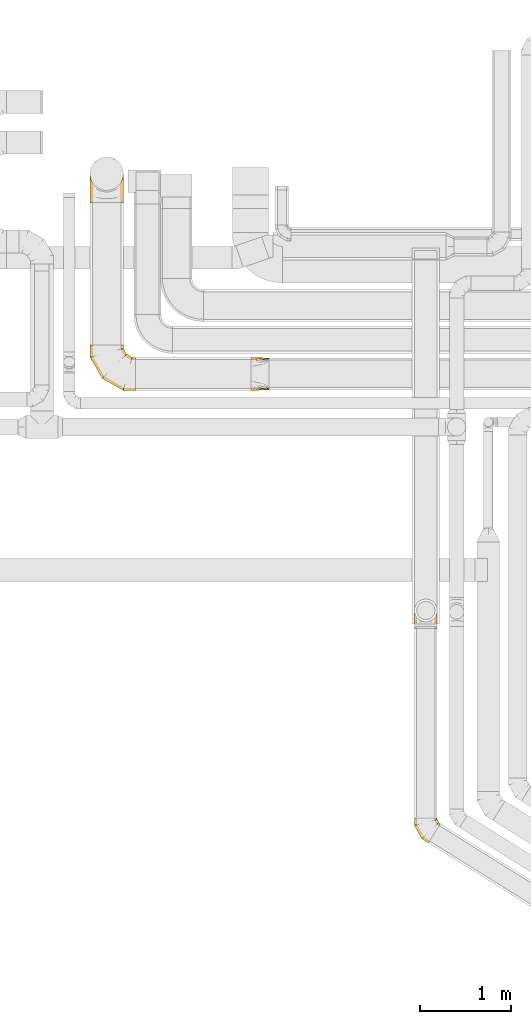
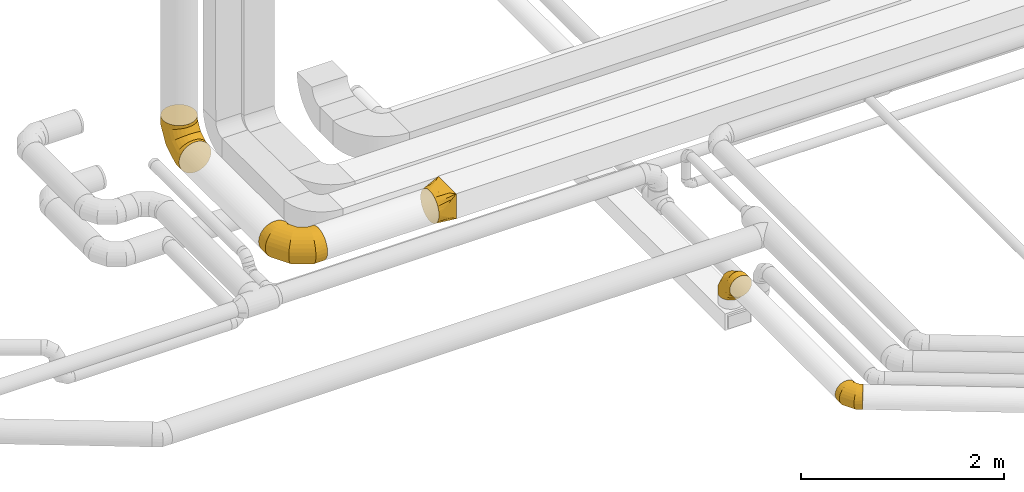
# One storey, part 8 of 92: 5 coverings.
"""IFC2X3 building model written with IfcOpenShell, lengths in millimetres."""

from ifc_helpers import new_model, entity, si_unit, converted_unit, derived_unit, direction, frame, origin, place, context, subcontext, project, spatial, faceted_brep, element, save


model = new_model("IFC2X3")

# Units and contexts
model_context = context("Model", 3, precision=0.01, world=origin(), true_north=direction((6.12303176911189e-17, 1.0)))
body_context = subcontext(model_context, "Body", "Model", "MODEL_VIEW")
ifc_project = project(units=[si_unit("LENGTHUNIT", "METRE", prefix="MILLI"), si_unit("AREAUNIT", "SQUARE_METRE"), si_unit("VOLUMEUNIT", "CUBIC_METRE"), converted_unit("PLANEANGLEUNIT", "DEGREE", entity("IfcRatioMeasure", 0.0174532925199433), si_unit("PLANEANGLEUNIT", "RADIAN"), dimensions=[0, 0, 0, 0, 0, 0, 0]), si_unit("MASSUNIT", "GRAM", prefix="KILO"), derived_unit("MASSDENSITYUNIT", [(si_unit("MASSUNIT", "GRAM", prefix="KILO"), 1), (si_unit("LENGTHUNIT", "METRE"), -3)]), derived_unit("MOMENTOFINERTIAUNIT", [(si_unit("LENGTHUNIT", "METRE"), 4)]), si_unit("TIMEUNIT", "SECOND"), si_unit("FREQUENCYUNIT", "HERTZ"), si_unit("THERMODYNAMICTEMPERATUREUNIT", "DEGREE_CELSIUS"), derived_unit("THERMALTRANSMITTANCEUNIT", [(si_unit("MASSUNIT", "GRAM", prefix="KILO"), 1), (si_unit("THERMODYNAMICTEMPERATUREUNIT", "KELVIN"), -1), (si_unit("TIMEUNIT", "SECOND"), -3)]), derived_unit("VOLUMETRICFLOWRATEUNIT", [(si_unit("LENGTHUNIT", "METRE"), 3), (si_unit("TIMEUNIT", "SECOND"), -1)]), derived_unit("MASSFLOWRATEUNIT", [(si_unit("MASSUNIT", "GRAM", prefix="KILO"), 1), (si_unit("TIMEUNIT", "SECOND"), -1)]), derived_unit("ROTATIONALFREQUENCYUNIT", [(si_unit("TIMEUNIT", "SECOND"), -1)]), si_unit("ELECTRICCURRENTUNIT", "AMPERE"), si_unit("ELECTRICVOLTAGEUNIT", "VOLT"), si_unit("POWERUNIT", "WATT"), si_unit("FORCEUNIT", "NEWTON", prefix="KILO"), si_unit("ILLUMINANCEUNIT", "LUX"), si_unit("LUMINOUSFLUXUNIT", "LUMEN"), si_unit("LUMINOUSINTENSITYUNIT", "CANDELA"), derived_unit("USERDEFINED", [(si_unit("MASSUNIT", "GRAM", prefix="KILO"), -1), (si_unit("LENGTHUNIT", "METRE"), -2), (si_unit("TIMEUNIT", "SECOND"), 3), (si_unit("LUMINOUSFLUXUNIT", "LUMEN"), 1)]), derived_unit("LINEARVELOCITYUNIT", [(si_unit("LENGTHUNIT", "METRE"), 1), (si_unit("TIMEUNIT", "SECOND"), -1)]), si_unit("PRESSUREUNIT", "PASCAL"), derived_unit("USERDEFINED", [(si_unit("LENGTHUNIT", "METRE"), -2), (si_unit("MASSUNIT", "GRAM", prefix="KILO"), 1), (si_unit("TIMEUNIT", "SECOND"), -2)]), derived_unit("LINEARFORCEUNIT", [(si_unit("MASSUNIT", "GRAM", prefix="KILO"), 1), (si_unit("LENGTHUNIT", "METRE"), 1), (si_unit("TIMEUNIT", "SECOND"), -2), (si_unit("LENGTHUNIT", "METRE"), -1)]), derived_unit("PLANARFORCEUNIT", [(si_unit("MASSUNIT", "GRAM", prefix="KILO"), 1), (si_unit("LENGTHUNIT", "METRE"), 1), (si_unit("TIMEUNIT", "SECOND"), -2), (si_unit("LENGTHUNIT", "METRE"), -2)])], contexts=[model_context])

# Site, building, storey
site_placement = place(None, origin())
site = spatial("IfcSite", under=ifc_project, at=site_placement, CompositionType="ELEMENT")
building_placement = place(site_placement, origin())
building = spatial("IfcBuilding", under=site, at=building_placement, CompositionType="ELEMENT")
storey_placement = place(building_placement, frame((0.0, 0.0, 4200.0)))
storey = spatial("IfcBuildingStorey", under=building, at=storey_placement, CompositionType="ELEMENT", Elevation=4200.0)

# Coverings
covering_1_placement = place(storey_placement, frame((11977.68, 6670.24, 3223.4)))
element("IfcCovering", 1, at=covering_1_placement, inside=storey, PredefinedType="INSULATION", context=body_context, shape_type="Brep", body=[
    faceted_brep([(283.61, 208.42, 87.97), (286.85, 213.61, 126.6), (283.61, 208.42, 165.22), (274.2, 193.36, 200.07), (259.55, 169.91, 227.72), (241.08, 140.36, 245.48), (220.61, 107.6, 251.6), (200.14, 74.84, 245.48), (181.68, 45.29, 227.72), (167.02, 21.84, 200.07), (157.62, 6.78, 165.22), (154.37, 1.6, 126.6), (157.62, 6.78, 87.97), (167.02, 21.84, 53.12), (181.68, 45.29, 25.47), (200.14, 74.84, 7.71), (220.61, 107.6, 1.6), (241.08, 140.36, 7.71), (259.55, 169.91, 25.47), (274.2, 193.36, 53.12), (5.85, 277.21, 94.24), (1.6, 277.21, 126.6), (5.85, 277.21, 158.95), (18.34, 277.21, 189.1), (38.21, 277.21, 214.98), (64.1, 277.21, 234.85), (94.24, 277.21, 247.34), (126.6, 277.21, 251.6), (158.95, 277.21, 247.34), (189.1, 277.21, 234.85), (214.98, 277.21, 214.98), (234.85, 277.21, 189.1), (247.34, 277.21, 158.95), (251.6, 277.21, 126.6), (247.34, 277.21, 94.24), (234.85, 277.21, 64.1), (214.98, 277.21, 38.21), (189.1, 277.21, 18.34), (158.95, 277.21, 5.85), (126.6, 277.21, 1.6), (94.24, 277.21, 5.85), (64.1, 277.21, 18.34), (38.21, 277.21, 38.21), (18.34, 277.21, 64.1), (1.6, 193.16, 126.6), (5.85, 194.26, 158.95), (18.34, 197.49, 189.1), (38.21, 202.63, 214.98), (64.1, 209.32, 234.85), (94.24, 217.12, 247.34), (126.6, 225.49, 251.6), (158.95, 233.86, 247.34), (189.1, 241.65, 234.85), (214.98, 248.35, 214.98), (234.85, 253.48, 189.1), (247.34, 256.71, 158.95), (251.6, 257.82, 126.6), (247.34, 256.71, 94.24), (234.85, 253.48, 64.1), (214.98, 248.35, 38.21), (158.95, 233.86, 5.85), (126.6, 225.49, 1.6), (189.1, 241.65, 18.34), (94.24, 217.12, 5.85), (64.1, 209.32, 18.34), (38.21, 202.63, 38.21), (18.34, 197.49, 64.1), (5.85, 194.26, 94.24), (83.09, 46.14, 126.6), (86.29, 49.16, 158.95), (95.64, 58.04, 189.1), (110.52, 72.17, 214.98), (129.92, 90.57, 234.85), (152.51, 112.01, 247.34), (176.75, 135.01, 251.6), (200.99, 158.01, 247.34), (223.58, 179.45, 234.85), (242.97, 197.86, 214.98), (257.86, 211.98, 189.1), (267.21, 220.86, 158.95), (270.4, 223.89, 126.6), (267.21, 220.86, 94.24), (257.86, 211.98, 64.1), (242.97, 197.86, 38.21), (200.99, 158.01, 5.85), (176.75, 135.01, 1.6), (223.58, 179.45, 18.34), (152.51, 112.01, 5.85), (129.92, 90.57, 18.34), (110.52, 72.17, 38.21), (95.64, 58.04, 64.1), (86.29, 49.16, 94.24)], [[[0, 1, 2, 3, 4, 5, 6, 7, 8, 9, 10, 11, 12, 13, 14, 15, 16, 17, 18, 19]], [[20, 21, 22, 23, 24, 25, 26, 27, 28, 29, 30, 31, 32, 33, 34, 35, 36, 37, 38, 39, 40, 41, 42, 43]], [[21, 44, 45, 22]], [[22, 45, 46, 23]], [[47, 24, 23, 46]], [[24, 47, 48, 25]], [[25, 48, 49, 26]], [[50, 27, 26, 49]], [[51, 52, 29, 28]], [[50, 51, 28, 27]], [[53, 30, 29, 52]], [[54, 55, 32, 31]], [[54, 31, 30, 53]], [[56, 33, 32, 55]], [[57, 58, 35, 34]], [[56, 57, 34, 33]], [[36, 35, 58, 59]], [[60, 61, 39, 38]], [[62, 60, 38, 37]], [[59, 62, 37, 36]], [[40, 39, 61, 63]], [[41, 40, 63, 64]], [[64, 65, 42, 41]], [[20, 43, 66, 67]], [[21, 20, 67, 44]], [[65, 66, 43, 42]], [[45, 44, 68, 69]], [[46, 45, 69, 70]], [[70, 71, 47, 46]], [[48, 47, 71, 72]], [[49, 48, 72, 73]], [[50, 49, 73, 74]], [[75, 76, 52, 51]], [[74, 75, 51, 50]], [[53, 52, 76, 77]], [[78, 79, 55, 54]], [[77, 78, 54, 53]], [[56, 55, 79, 80]], [[81, 82, 58, 57]], [[80, 81, 57, 56]], [[59, 58, 82, 83]], [[84, 85, 61, 60]], [[86, 84, 60, 62]], [[83, 86, 62, 59]], [[63, 61, 85, 87]], [[64, 63, 87, 88]], [[65, 64, 88, 89]], [[67, 66, 90, 91]], [[44, 67, 91, 68]], [[89, 90, 66, 65]], [[69, 11, 10]], [[70, 10, 9]], [[11, 69, 68]], [[69, 10, 70]], [[9, 71, 70]], [[72, 8, 7]], [[73, 7, 6]], [[71, 8, 72]], [[72, 7, 73]], [[6, 74, 73]], [[8, 71, 9]], [[75, 6, 5]], [[76, 5, 4]], [[75, 74, 6]], [[76, 75, 5]], [[4, 77, 76]], [[78, 3, 2]], [[79, 2, 1]], [[78, 77, 3]], [[80, 79, 1]], [[78, 2, 79]], [[3, 77, 4]], [[81, 1, 0]], [[82, 0, 19]], [[81, 80, 1]], [[82, 81, 0]], [[19, 83, 82]], [[86, 18, 17]], [[84, 17, 16]], [[86, 83, 18]], [[85, 84, 16]], [[86, 17, 84]], [[18, 83, 19]], [[87, 16, 15]], [[88, 15, 14]], [[16, 87, 85]], [[87, 15, 88]], [[14, 89, 88]], [[90, 13, 12]], [[91, 12, 11]], [[89, 13, 90]], [[91, 90, 12]], [[68, 91, 11]], [[13, 89, 14]]]),
])
covering_2_placement = place(storey_placement, frame((8417.31, 11635.59, 3108.4)))
element("IfcCovering", 2, at=covering_2_placement, inside=storey, PredefinedType="INSULATION", context=body_context, shape_type="Brep", body=[
    faceted_brep([(499.1, 26.05, 275.35), (499.1, 7.81, 231.33), (499.1, 1.6, 184.1), (499.1, 7.81, 136.86), (499.1, 26.05, 92.85), (499.1, 55.05, 55.05), (499.1, 92.85, 26.05), (499.1, 136.86, 7.81), (499.1, 184.1, 1.6), (499.1, 231.33, 7.81), (499.1, 275.35, 26.05), (499.1, 313.14, 55.05), (499.1, 342.14, 92.85), (499.1, 360.38, 136.86), (499.1, 366.6, 184.1), (499.1, 360.38, 231.33), (499.1, 342.14, 275.35), (499.1, 313.14, 313.14), (499.1, 275.35, 342.14), (499.1, 231.33, 360.38), (499.1, 184.1, 366.6), (499.1, 136.86, 360.38), (499.1, 92.85, 342.14), (499.1, 55.05, 313.14), (26.05, 499.1, 92.85), (7.81, 499.1, 136.86), (1.6, 499.1, 184.1), (7.81, 499.1, 231.33), (26.05, 499.1, 275.35), (55.05, 499.1, 313.14), (92.85, 499.1, 342.14), (136.86, 499.1, 360.38), (184.1, 499.1, 366.6), (231.33, 499.1, 360.38), (275.35, 499.1, 342.14), (313.14, 499.1, 313.14), (342.14, 499.1, 275.35), (360.38, 499.1, 231.33), (366.6, 499.1, 184.1), (360.38, 499.1, 136.86), (342.14, 499.1, 92.85), (313.14, 499.1, 55.05), (275.35, 499.1, 26.05), (231.33, 499.1, 7.81), (184.1, 499.1, 1.6), (136.86, 499.1, 7.81), (92.85, 499.1, 26.05), (55.05, 499.1, 55.05), (1.6, 365.79, 184.1), (6.17, 367.02, 224.71), (19.67, 370.63, 263.28), (41.41, 376.46, 297.88), (70.31, 384.2, 326.78), (104.91, 393.47, 348.52), (143.49, 403.81, 362.02), (184.1, 414.69, 366.6), (224.71, 425.57, 362.02), (263.28, 435.91, 348.52), (297.88, 445.18, 326.78), (326.78, 452.92, 297.88), (348.52, 458.75, 263.28), (362.02, 462.37, 224.71), (366.6, 463.59, 184.1), (348.52, 458.75, 104.91), (326.78, 452.92, 70.31), (362.02, 462.37, 143.49), (297.88, 445.18, 41.41), (263.28, 435.91, 19.67), (224.71, 425.57, 6.17), (184.1, 414.69, 1.6), (143.49, 403.81, 6.17), (104.91, 393.47, 19.67), (70.31, 384.2, 41.41), (41.41, 376.46, 70.31), (19.67, 370.63, 104.91), (6.17, 367.02, 143.49), (134.9, 134.9, 184.1), (138.25, 138.25, 224.71), (148.13, 148.13, 263.28), (164.05, 164.05, 297.88), (185.2, 185.2, 326.78), (210.53, 210.53, 348.52), (238.77, 238.77, 362.02), (268.5, 268.5, 366.6), (298.23, 298.23, 362.02), (326.47, 326.47, 348.52), (351.8, 351.8, 326.78), (372.95, 372.95, 297.88), (388.87, 388.87, 263.28), (398.75, 398.75, 224.71), (402.1, 402.1, 184.1), (398.75, 398.75, 143.49), (388.87, 388.87, 104.91), (372.95, 372.95, 70.31), (351.8, 351.8, 41.41), (326.47, 326.47, 19.67), (298.23, 298.23, 6.17), (268.5, 268.5, 1.6), (238.77, 238.77, 6.17), (210.53, 210.53, 19.67), (185.2, 185.2, 41.41), (164.05, 164.05, 70.31), (148.13, 148.13, 104.91), (138.25, 138.25, 143.49), (365.79, 1.6, 184.1), (367.02, 6.17, 224.71), (370.63, 19.67, 263.28), (376.46, 41.41, 297.88), (384.2, 70.31, 326.78), (393.47, 104.91, 348.52), (403.81, 143.49, 362.02), (414.69, 184.1, 366.6), (425.57, 224.71, 362.02), (435.91, 263.28, 348.52), (445.18, 297.88, 326.78), (452.92, 326.78, 297.88), (458.75, 348.52, 263.28), (462.37, 362.02, 224.71), (463.59, 366.6, 184.1), (462.37, 362.02, 143.49), (458.75, 348.52, 104.91), (452.92, 326.78, 70.31), (445.18, 297.88, 41.41), (435.91, 263.28, 19.67), (425.57, 224.71, 6.17), (414.69, 184.1, 1.6), (403.81, 143.49, 6.17), (393.47, 104.91, 19.67), (384.2, 70.31, 41.41), (376.46, 41.41, 70.31), (370.63, 19.67, 104.91), (367.02, 6.17, 143.49)], [[[0, 1, 2, 3, 4, 5, 6, 7, 8, 9, 10, 11, 12, 13, 14, 15, 16, 17, 18, 19, 20, 21, 22, 23]], [[24, 25, 26, 27, 28, 29, 30, 31, 32, 33, 34, 35, 36, 37, 38, 39, 40, 41, 42, 43, 44, 45, 46, 47]], [[26, 48, 49]], [[27, 49, 50]], [[26, 49, 27]], [[28, 51, 29]], [[28, 27, 50]], [[51, 28, 50]], [[30, 52, 53]], [[31, 53, 54]], [[32, 54, 55]], [[29, 52, 30]], [[30, 53, 31]], [[54, 32, 31]], [[52, 29, 51]], [[56, 57, 33]], [[55, 56, 32]], [[32, 56, 33]], [[34, 58, 35]], [[34, 33, 57]], [[58, 34, 57]], [[59, 60, 36]], [[61, 62, 38]], [[60, 61, 37]], [[35, 59, 36]], [[36, 60, 37]], [[61, 38, 37]], [[59, 35, 58]], [[63, 64, 40]], [[65, 63, 39]], [[62, 65, 38]], [[38, 65, 39]], [[63, 40, 39]], [[64, 41, 40]], [[66, 67, 42]], [[68, 69, 44]], [[67, 68, 43]], [[41, 66, 42]], [[42, 67, 43]], [[68, 44, 43]], [[66, 41, 64]], [[45, 70, 71]], [[46, 71, 72]], [[69, 70, 44]], [[44, 70, 45]], [[71, 46, 45]], [[72, 47, 46]], [[24, 73, 74]], [[74, 75, 25]], [[48, 26, 75]], [[47, 73, 24]], [[24, 74, 25]], [[75, 26, 25]], [[73, 47, 72]], [[49, 48, 76, 77]], [[49, 77, 78, 50]], [[51, 50, 78, 79]], [[79, 80, 52, 51]], [[53, 52, 80, 81]], [[54, 53, 81, 82]], [[55, 54, 82, 83]], [[83, 84, 56, 55]], [[85, 86, 58, 57]], [[84, 85, 57, 56]], [[86, 87, 59, 58]], [[87, 88, 60, 59]], [[89, 90, 62, 61]], [[88, 89, 61, 60]], [[90, 91, 65, 62]], [[92, 93, 64, 63]], [[91, 92, 63, 65]], [[93, 94, 66, 64]], [[94, 95, 67, 66]], [[96, 97, 69, 68]], [[95, 96, 68, 67]], [[70, 69, 97, 98]], [[98, 99, 71, 70]], [[100, 72, 71, 99]], [[100, 101, 73, 72]], [[74, 73, 101, 102]], [[102, 103, 75, 74]], [[76, 48, 75, 103]], [[77, 76, 104, 105]], [[77, 105, 106, 78]], [[79, 78, 106, 107]], [[107, 108, 80, 79]], [[81, 80, 108, 109]], [[82, 81, 109, 110]], [[83, 82, 110, 111]], [[111, 112, 84, 83]], [[113, 114, 86, 85]], [[112, 113, 85, 84]], [[114, 115, 87, 86]], [[115, 116, 88, 87]], [[117, 118, 90, 89]], [[116, 117, 89, 88]], [[118, 119, 91, 90]], [[120, 121, 93, 92]], [[119, 120, 92, 91]], [[121, 122, 94, 93]], [[122, 123, 95, 94]], [[124, 125, 97, 96]], [[123, 124, 96, 95]], [[98, 97, 125, 126]], [[126, 127, 99, 98]], [[128, 100, 99, 127]], [[128, 129, 101, 100]], [[102, 101, 129, 130]], [[130, 131, 103, 102]], [[104, 76, 103, 131]], [[105, 2, 1]], [[106, 1, 0]], [[104, 2, 105]], [[105, 1, 106]], [[0, 107, 106]], [[0, 23, 107]], [[108, 23, 22]], [[109, 22, 21]], [[110, 21, 20]], [[108, 22, 109]], [[109, 21, 110]], [[20, 111, 110]], [[23, 108, 107]], [[112, 20, 19]], [[113, 19, 18]], [[112, 111, 20]], [[114, 113, 18]], [[112, 19, 113]], [[18, 17, 114]], [[115, 17, 16]], [[116, 16, 15]], [[117, 15, 14]], [[116, 115, 16]], [[118, 117, 14]], [[116, 15, 117]], [[17, 115, 114]], [[119, 14, 13]], [[120, 13, 12]], [[119, 118, 14]], [[121, 120, 12]], [[119, 13, 120]], [[12, 11, 121]], [[122, 11, 10]], [[123, 10, 9]], [[124, 9, 8]], [[123, 122, 10]], [[125, 124, 8]], [[123, 9, 124]], [[11, 122, 121]], [[126, 8, 7]], [[127, 7, 6]], [[125, 8, 126]], [[127, 126, 7]], [[128, 127, 6]], [[6, 5, 128]], [[129, 5, 4]], [[130, 4, 3]], [[131, 3, 2]], [[129, 4, 130]], [[131, 130, 3]], [[104, 131, 2]], [[5, 129, 128]]]),
])
covering_3_placement = place(storey_placement, frame((10183.35, 11635.59, 3108.4)))
element("IfcCovering", 3, at=covering_3_placement, inside=storey, PredefinedType="INSULATION", context=body_context, shape_type="Brep", body=[
    faceted_brep([(0.0, 55.05, 313.14), (0.0, 73.95, 327.64), (0.0, 92.85, 342.14), (0.0, 114.85, 351.26), (0.0, 136.86, 360.38), (0.0, 151.73, 362.33), (0.0, 166.6, 364.29), (0.0, 184.1, 366.6), (0.0, 201.59, 364.29), (0.0, 216.46, 362.33), (0.0, 231.33, 360.38), (0.0, 253.34, 351.26), (0.0, 275.35, 342.14), (0.0, 294.24, 327.64), (0.0, 313.14, 313.14), (0.0, 327.64, 294.24), (0.0, 342.14, 275.35), (0.0, 351.26, 253.34), (0.0, 360.38, 231.33), (0.0, 362.33, 216.46), (0.0, 364.29, 201.59), (0.0, 366.6, 184.1), (0.0, 364.29, 166.6), (0.0, 362.33, 151.73), (0.0, 360.38, 136.86), (0.0, 351.26, 114.85), (0.0, 342.14, 92.85), (0.0, 327.64, 73.95), (0.0, 313.14, 55.05), (0.0, 294.24, 40.55), (0.0, 275.35, 26.05), (0.0, 253.34, 16.93), (0.0, 231.33, 7.81), (0.0, 216.46, 5.86), (0.0, 201.59, 3.9), (0.0, 184.1, 1.6), (0.0, 166.6, 3.9), (0.0, 151.73, 5.86), (0.0, 136.86, 7.81), (0.0, 114.85, 16.93), (0.0, 92.85, 26.05), (0.0, 73.95, 40.55), (0.0, 55.05, 55.05), (0.0, 40.55, 73.95), (0.0, 26.05, 92.85), (0.0, 16.93, 114.85), (0.0, 7.81, 136.86), (0.0, 5.86, 151.73), (0.0, 3.9, 166.6), (0.0, 1.6, 184.1), (0.0, 3.9, 201.59), (0.0, 5.86, 216.46), (0.0, 7.81, 231.33), (0.0, 16.93, 253.34), (0.0, 26.05, 275.35), (0.0, 40.55, 294.24), (200.0, 9.1, 366.6), (200.0, 9.1, 66.6), (200.0, 359.1, 66.6), (200.0, 359.1, 366.6), (71.91, 121.17, 24.97), (95.89, 100.2, 32.76), (121.91, 77.42, 41.22), (100.0, 36.1, 57.03), (173.97, 31.87, 58.14), (147.94, 7.14, 97.18), (173.97, 8.12, 81.89), (121.91, 6.17, 112.47), (95.89, 5.19, 127.76), (71.91, 4.29, 141.85), (23.97, 163.12, 9.39), (47.94, 142.15, 17.18), (47.94, 3.39, 155.93), (23.97, 2.49, 170.01), (147.94, 54.65, 49.68), (173.97, 8.12, 342.84), (147.94, 7.14, 319.09), (121.91, 6.17, 295.34), (95.89, 5.19, 271.59), (71.91, 4.29, 249.72), (47.94, 3.39, 227.84), (23.97, 2.49, 205.97), (100.0, 28.28, 335.85), (147.94, 54.65, 366.6), (173.97, 31.87, 366.6), (121.91, 77.42, 366.6), (95.89, 100.2, 366.6), (71.91, 121.17, 366.6), (47.94, 142.15, 366.6), (23.97, 163.12, 366.6), (173.97, 336.32, 366.6), (147.94, 313.55, 366.6), (121.91, 290.77, 366.6), (95.89, 268.0, 366.6), (71.91, 247.02, 366.6), (47.94, 226.05, 366.6), (23.97, 205.07, 366.6), (100.0, 332.1, 343.66), (147.94, 361.05, 319.09), (173.97, 360.07, 342.84), (121.91, 362.02, 295.34), (95.89, 363.0, 271.59), (71.91, 363.9, 249.72), (47.94, 364.8, 227.84), (23.97, 365.7, 205.97), (173.97, 360.07, 81.89), (147.94, 361.05, 97.18), (121.91, 362.02, 112.47), (95.89, 363.0, 127.76), (71.91, 363.9, 141.85), (47.94, 364.8, 155.93), (23.97, 365.7, 170.01), (100.0, 339.91, 64.85), (147.94, 313.55, 49.68), (173.97, 336.32, 58.14), (121.91, 290.77, 41.22), (95.89, 268.0, 32.76), (71.91, 247.02, 24.97), (47.94, 226.05, 17.18), (23.97, 205.07, 9.39)], [[[0, 1, 2, 3, 4, 5, 6, 7, 8, 9, 10, 11, 12, 13, 14, 15, 16, 17, 18, 19, 20, 21, 22, 23, 24, 25, 26, 27, 28, 29, 30, 31, 32, 33, 34, 35, 36, 37, 38, 39, 40, 41, 42, 43, 44, 45, 46, 47, 48, 49, 50, 51, 52, 53, 54, 55]], [[56, 57, 58, 59]], [[60, 61, 62, 39]], [[63, 41, 64]], [[43, 42, 63]], [[38, 60, 39]], [[39, 62, 40]], [[65, 44, 43]], [[43, 63, 66]], [[45, 67, 68, 69]], [[70, 71, 60, 38, 37, 36, 35]], [[47, 46, 69, 72, 73, 49, 48]], [[45, 44, 67]], [[45, 69, 46]], [[44, 65, 67]], [[41, 74, 64]], [[41, 40, 74]], [[57, 63, 64]], [[41, 63, 42]], [[43, 66, 65]], [[63, 57, 66]], [[62, 74, 40]], [[57, 56, 75, 76, 77, 78, 79, 80, 81, 49, 73, 72, 69, 68, 67, 65, 66]], [[79, 78, 77, 53]], [[82, 55, 75]], [[1, 0, 82]], [[52, 79, 53]], [[53, 77, 54]], [[83, 2, 1]], [[1, 82, 84]], [[3, 85, 86, 87]], [[81, 80, 79, 52, 51, 50, 49]], [[5, 4, 87, 88, 89, 7, 6]], [[3, 2, 85]], [[3, 87, 4]], [[2, 83, 85]], [[55, 76, 75]], [[55, 54, 76]], [[56, 82, 75]], [[55, 82, 0]], [[1, 84, 83]], [[82, 56, 84]], [[77, 76, 54]], [[56, 59, 90, 91, 92, 93, 94, 95, 96, 7, 89, 88, 87, 86, 85, 83, 84]], [[94, 93, 92, 11]], [[97, 13, 90]], [[15, 14, 97]], [[10, 94, 11]], [[11, 92, 12]], [[98, 16, 15]], [[15, 97, 99]], [[17, 100, 101, 102]], [[96, 95, 94, 10, 9, 8, 7]], [[19, 18, 102, 103, 104, 21, 20]], [[17, 16, 100]], [[17, 102, 18]], [[16, 98, 100]], [[13, 91, 90]], [[13, 12, 91]], [[59, 97, 90]], [[13, 97, 14]], [[15, 99, 98]], [[97, 59, 99]], [[92, 91, 12]], [[104, 103, 102, 101, 100, 98, 99, 59, 58, 105, 106, 107, 108, 109, 110, 111, 21]], [[109, 108, 107, 25]], [[112, 27, 105]], [[29, 28, 112]], [[24, 109, 25]], [[25, 107, 26]], [[113, 30, 29]], [[29, 112, 114]], [[31, 115, 116, 117]], [[111, 110, 109, 24, 23, 22, 21]], [[33, 32, 117, 118, 119, 35, 34]], [[31, 30, 115]], [[31, 117, 32]], [[30, 113, 115]], [[27, 106, 105]], [[27, 26, 106]], [[58, 112, 105]], [[27, 112, 28]], [[29, 114, 113]], [[112, 58, 114]], [[107, 106, 26]], [[58, 57, 64, 74, 62, 61, 60, 71, 70, 35, 119, 118, 117, 116, 115, 113, 114]]]),
])
covering_4_placement = place(storey_placement, frame((11977.68, 9022.49, 3150.0)))
element("IfcCovering", 4, at=covering_4_placement, inside=storey, PredefinedType="INSULATION", context=body_context, shape_type="Brep", body=[
    faceted_brep([(1.6, 200.0, 0.0), (7.71, 238.63, 0.0), (25.47, 273.47, 0.0), (53.12, 301.13, 0.0), (87.97, 318.88, 0.0), (126.6, 325.0, 0.0), (165.22, 318.88, 0.0), (200.07, 301.13, 0.0), (227.72, 273.47, 0.0), (245.48, 238.63, 0.0), (251.6, 200.0, 0.0), (245.48, 161.37, 0.0), (227.72, 126.53, 0.0), (200.07, 98.87, 0.0), (165.22, 81.12, 0.0), (126.6, 75.0, 0.0), (87.97, 81.12, 0.0), (53.12, 98.87, 0.0), (25.47, 126.53, 0.0), (7.71, 161.37, 0.0), (189.1, 0.0, 308.25), (158.95, 0.0, 320.74), (126.6, 0.0, 325.0), (94.24, 0.0, 320.74), (64.1, 0.0, 308.25), (38.21, 0.0, 288.39), (18.34, 0.0, 262.5), (5.85, 0.0, 232.35), (1.6, 0.0, 200.0), (5.85, 0.0, 167.65), (18.34, 0.0, 137.5), (38.21, 0.0, 111.61), (64.1, 0.0, 91.75), (94.24, 0.0, 79.26), (126.6, 0.0, 75.0), (158.95, 0.0, 79.26), (189.1, 0.0, 91.75), (214.98, 0.0, 111.61), (234.85, 0.0, 137.5), (247.34, 0.0, 167.65), (251.6, 0.0, 200.0), (247.34, 0.0, 232.35), (234.85, 0.0, 262.5), (214.98, 0.0, 288.39), (126.6, 87.08, 325.0), (94.24, 85.94, 320.74), (64.1, 82.6, 308.25), (38.21, 77.27, 288.39), (18.34, 70.34, 262.5), (5.85, 62.26, 232.35), (1.6, 53.59, 200.0), (5.85, 44.92, 167.65), (18.34, 36.84, 137.5), (38.21, 29.91, 111.61), (64.1, 24.58, 91.75), (94.24, 21.24, 79.26), (126.6, 20.1, 75.0), (158.95, 21.24, 79.26), (189.1, 24.58, 91.75), (214.98, 29.91, 111.61), (247.34, 44.92, 167.65), (251.6, 53.59, 200.0), (234.85, 36.84, 137.5), (247.34, 62.26, 232.35), (234.85, 70.34, 262.5), (214.98, 77.27, 288.39), (189.1, 82.6, 308.25), (158.95, 85.94, 320.74), (126.6, 237.92, 237.92), (94.24, 234.8, 234.8), (64.1, 225.66, 225.66), (38.21, 211.11, 211.11), (18.34, 192.16, 192.16), (5.85, 170.09, 170.09), (1.6, 146.41, 146.41), (5.85, 122.73, 122.73), (18.34, 100.66, 100.66), (38.21, 81.71, 81.71), (64.1, 67.16, 67.16), (94.24, 58.02, 58.02), (126.6, 54.9, 54.9), (158.95, 58.02, 58.02), (189.1, 67.16, 67.16), (214.98, 81.71, 81.71), (247.34, 122.73, 122.73), (251.6, 146.41, 146.41), (234.85, 100.66, 100.66), (247.34, 170.09, 170.09), (234.85, 192.16, 192.16), (214.98, 211.11, 211.11), (189.1, 225.66, 225.66), (158.95, 234.8, 234.8), (126.6, 325.0, 87.08), (94.24, 320.74, 85.94), (64.1, 308.25, 82.6), (38.21, 288.39, 77.27), (18.34, 262.5, 70.34), (5.85, 232.35, 62.26), (1.6, 200.0, 53.59), (5.85, 167.65, 44.92), (18.34, 137.5, 36.84), (38.21, 111.61, 29.91), (64.1, 91.75, 24.58), (94.24, 79.26, 21.24), (126.6, 75.0, 20.1), (158.95, 79.26, 21.24), (189.1, 91.75, 24.58), (214.98, 111.61, 29.91), (247.34, 167.65, 44.92), (251.6, 200.0, 53.59), (234.85, 137.5, 36.84), (247.34, 232.35, 62.26), (234.85, 262.5, 70.34), (214.98, 288.39, 77.27), (189.1, 308.25, 82.6), (158.95, 320.74, 85.94)], [[[0, 1, 2, 3, 4, 5, 6, 7, 8, 9, 10, 11, 12, 13, 14, 15, 16, 17, 18, 19]], [[20, 21, 22, 23, 24, 25, 26, 27, 28, 29, 30, 31, 32, 33, 34, 35, 36, 37, 38, 39, 40, 41, 42, 43]], [[22, 44, 45, 23]], [[23, 45, 46, 24]], [[47, 25, 24, 46]], [[25, 47, 48, 26]], [[26, 48, 49, 27]], [[50, 28, 27, 49]], [[51, 52, 30, 29]], [[50, 51, 29, 28]], [[53, 31, 30, 52]], [[54, 55, 33, 32]], [[54, 32, 31, 53]], [[56, 34, 33, 55]], [[57, 58, 36, 35]], [[56, 57, 35, 34]], [[37, 36, 58, 59]], [[60, 61, 40, 39]], [[62, 60, 39, 38]], [[59, 62, 38, 37]], [[41, 40, 61, 63]], [[42, 41, 63, 64]], [[64, 65, 43, 42]], [[21, 20, 66, 67]], [[22, 21, 67, 44]], [[65, 66, 20, 43]], [[45, 44, 68, 69]], [[46, 45, 69, 70]], [[70, 71, 47, 46]], [[48, 47, 71, 72]], [[49, 48, 72, 73]], [[50, 49, 73, 74]], [[75, 76, 52, 51]], [[74, 75, 51, 50]], [[53, 52, 76, 77]], [[78, 79, 55, 54]], [[77, 78, 54, 53]], [[56, 55, 79, 80]], [[81, 82, 58, 57]], [[80, 81, 57, 56]], [[59, 58, 82, 83]], [[84, 85, 61, 60]], [[86, 84, 60, 62]], [[83, 86, 62, 59]], [[63, 61, 85, 87]], [[64, 63, 87, 88]], [[65, 64, 88, 89]], [[67, 66, 90, 91]], [[44, 67, 91, 68]], [[89, 90, 66, 65]], [[69, 68, 92, 93]], [[70, 69, 93, 94]], [[94, 95, 71, 70]], [[72, 71, 95, 96]], [[73, 72, 96, 97]], [[74, 73, 97, 98]], [[99, 100, 76, 75]], [[98, 99, 75, 74]], [[77, 76, 100, 101]], [[102, 103, 79, 78]], [[101, 102, 78, 77]], [[80, 79, 103, 104]], [[105, 106, 82, 81]], [[104, 105, 81, 80]], [[83, 82, 106, 107]], [[108, 109, 85, 84]], [[110, 108, 84, 86]], [[107, 110, 86, 83]], [[87, 85, 109, 111]], [[88, 87, 111, 112]], [[89, 88, 112, 113]], [[91, 90, 114, 115]], [[68, 91, 115, 92]], [[113, 114, 90, 89]], [[93, 5, 4]], [[94, 4, 3]], [[5, 93, 92]], [[93, 4, 94]], [[3, 95, 94]], [[96, 2, 1]], [[97, 1, 0]], [[95, 2, 96]], [[96, 1, 97]], [[0, 98, 97]], [[2, 95, 3]], [[99, 0, 19]], [[100, 19, 18]], [[99, 98, 0]], [[100, 99, 19]], [[18, 101, 100]], [[16, 15, 103]], [[17, 16, 102]], [[102, 101, 17]], [[104, 103, 15]], [[102, 16, 103]], [[17, 101, 18]], [[105, 15, 14]], [[106, 14, 13]], [[105, 104, 15]], [[106, 105, 14]], [[13, 107, 106]], [[110, 12, 11]], [[108, 11, 10]], [[110, 107, 12]], [[109, 108, 10]], [[110, 11, 108]], [[12, 107, 13]], [[111, 10, 9]], [[112, 9, 8]], [[10, 111, 109]], [[111, 9, 112]], [[8, 113, 112]], [[114, 7, 6]], [[115, 6, 5]], [[113, 7, 114]], [[115, 114, 6]], [[92, 115, 5]], [[7, 113, 8]]]),
])
covering_5_placement = place(storey_placement, frame((8417.31, 13701.72, 3108.4)))
element("IfcCovering", 5, at=covering_5_placement, inside=storey, PredefinedType="INSULATION", context=body_context, shape_type="Brep", body=[
    faceted_brep([(275.35, 473.05, 499.1), (231.33, 491.28, 499.1), (184.1, 497.5, 499.1), (136.86, 491.28, 499.1), (92.85, 473.05, 499.1), (55.05, 444.05, 499.1), (26.05, 406.25, 499.1), (7.81, 362.23, 499.1), (1.6, 315.0, 499.1), (7.81, 267.77, 499.1), (26.05, 223.75, 499.1), (55.05, 185.95, 499.1), (92.85, 156.95, 499.1), (136.86, 138.72, 499.1), (184.1, 132.5, 499.1), (231.33, 138.72, 499.1), (275.35, 156.95, 499.1), (313.14, 185.95, 499.1), (342.14, 223.75, 499.1), (360.38, 267.77, 499.1), (366.6, 315.0, 499.1), (360.38, 362.23, 499.1), (342.14, 406.25, 499.1), (313.14, 444.05, 499.1), (92.85, 0.0, 26.05), (136.86, 0.0, 7.81), (184.1, 0.0, 1.6), (231.33, 0.0, 7.81), (275.35, 0.0, 26.05), (313.14, 0.0, 55.05), (342.14, 0.0, 92.85), (360.38, 0.0, 136.86), (366.6, 0.0, 184.1), (360.38, 0.0, 231.33), (342.14, 0.0, 275.35), (313.14, 0.0, 313.14), (275.35, 0.0, 342.14), (231.33, 0.0, 360.38), (184.1, 0.0, 366.6), (136.86, 0.0, 360.38), (92.85, 0.0, 342.14), (55.05, 0.0, 313.14), (26.05, 0.0, 275.35), (7.81, 0.0, 231.33), (1.6, 0.0, 184.1), (7.81, 0.0, 136.86), (26.05, 0.0, 92.85), (55.05, 0.0, 55.05), (184.1, 133.3, 1.6), (224.71, 132.08, 6.17), (263.28, 128.46, 19.67), (297.88, 122.64, 41.41), (326.78, 114.89, 70.31), (348.52, 105.62, 104.91), (362.02, 95.29, 143.49), (366.6, 84.4, 184.1), (362.02, 73.52, 224.71), (348.52, 63.19, 263.28), (326.78, 53.91, 297.88), (297.88, 46.17, 326.78), (263.28, 40.35, 348.52), (224.71, 36.73, 362.02), (184.1, 35.5, 366.6), (104.91, 40.35, 348.52), (70.31, 46.17, 326.78), (143.49, 36.73, 362.02), (41.41, 53.91, 297.88), (19.67, 63.19, 263.28), (6.17, 73.52, 224.71), (1.6, 84.4, 184.1), (6.17, 95.29, 143.49), (19.67, 105.62, 104.91), (41.41, 114.89, 70.31), (70.31, 122.64, 41.41), (104.91, 128.46, 19.67), (143.49, 132.08, 6.17), (184.1, 364.2, 134.9), (224.71, 360.85, 138.25), (263.28, 350.96, 148.13), (297.88, 335.05, 164.05), (326.78, 313.89, 185.2), (348.52, 288.56, 210.53), (362.02, 260.32, 238.77), (366.6, 230.6, 268.5), (362.02, 200.87, 298.23), (348.52, 172.63, 326.47), (326.78, 147.3, 351.8), (297.88, 126.14, 372.95), (263.28, 110.23, 388.87), (224.71, 100.35, 398.75), (184.1, 97.0, 402.1), (143.49, 100.35, 398.75), (104.91, 110.23, 388.87), (70.31, 126.14, 372.95), (41.41, 147.3, 351.8), (19.67, 172.63, 326.47), (6.17, 200.87, 298.23), (1.6, 230.6, 268.5), (6.17, 260.32, 238.77), (19.67, 288.56, 210.53), (41.41, 313.89, 185.2), (70.31, 335.05, 164.05), (104.91, 350.96, 148.13), (143.49, 360.85, 138.25), (184.1, 497.5, 365.79), (224.71, 492.92, 367.02), (263.28, 479.43, 370.63), (297.88, 457.68, 376.46), (326.78, 428.79, 384.2), (348.52, 394.18, 393.47), (362.02, 355.61, 403.81), (366.6, 315.0, 414.69), (362.02, 274.39, 425.57), (348.52, 235.82, 435.91), (326.78, 201.21, 445.18), (297.88, 172.32, 452.92), (263.28, 150.57, 458.75), (224.71, 137.08, 462.37), (184.1, 132.5, 463.59), (143.49, 137.08, 462.37), (104.91, 150.57, 458.75), (70.31, 172.32, 452.92), (41.41, 201.21, 445.18), (19.67, 235.82, 435.91), (6.17, 274.39, 425.57), (1.6, 315.0, 414.69), (6.17, 355.61, 403.81), (19.67, 394.18, 393.47), (41.41, 428.79, 384.2), (70.31, 457.68, 376.46), (104.91, 479.43, 370.63), (143.49, 492.92, 367.02)], [[[0, 1, 2, 3, 4, 5, 6, 7, 8, 9, 10, 11, 12, 13, 14, 15, 16, 17, 18, 19, 20, 21, 22, 23]], [[24, 25, 26, 27, 28, 29, 30, 31, 32, 33, 34, 35, 36, 37, 38, 39, 40, 41, 42, 43, 44, 45, 46, 47]], [[26, 48, 49]], [[27, 49, 50]], [[26, 49, 27]], [[28, 51, 29]], [[28, 27, 50]], [[51, 28, 50]], [[30, 52, 53]], [[31, 53, 54]], [[32, 54, 55]], [[29, 52, 30]], [[30, 53, 31]], [[54, 32, 31]], [[52, 29, 51]], [[56, 57, 33]], [[55, 56, 32]], [[32, 56, 33]], [[34, 58, 35]], [[34, 33, 57]], [[58, 34, 57]], [[59, 60, 36]], [[61, 62, 38]], [[60, 61, 37]], [[35, 59, 36]], [[36, 60, 37]], [[61, 38, 37]], [[59, 35, 58]], [[63, 64, 40]], [[65, 63, 39]], [[62, 65, 38]], [[38, 65, 39]], [[63, 40, 39]], [[64, 41, 40]], [[66, 67, 42]], [[68, 69, 44]], [[67, 68, 43]], [[41, 66, 42]], [[42, 67, 43]], [[68, 44, 43]], [[66, 41, 64]], [[45, 70, 71]], [[46, 71, 72]], [[69, 70, 44]], [[44, 70, 45]], [[71, 46, 45]], [[72, 47, 46]], [[24, 73, 74]], [[74, 75, 25]], [[48, 26, 75]], [[47, 73, 24]], [[24, 74, 25]], [[75, 26, 25]], [[73, 47, 72]], [[49, 48, 76, 77]], [[49, 77, 78, 50]], [[51, 50, 78, 79]], [[79, 80, 52, 51]], [[53, 52, 80, 81]], [[54, 53, 81, 82]], [[55, 54, 82, 83]], [[83, 84, 56, 55]], [[85, 86, 58, 57]], [[84, 85, 57, 56]], [[86, 87, 59, 58]], [[87, 88, 60, 59]], [[89, 90, 62, 61]], [[88, 89, 61, 60]], [[90, 91, 65, 62]], [[92, 93, 64, 63]], [[91, 92, 63, 65]], [[93, 94, 66, 64]], [[94, 95, 67, 66]], [[96, 97, 69, 68]], [[95, 96, 68, 67]], [[70, 69, 97, 98]], [[98, 99, 71, 70]], [[100, 72, 71, 99]], [[100, 101, 73, 72]], [[74, 73, 101, 102]], [[102, 103, 75, 74]], [[76, 48, 75, 103]], [[77, 76, 104, 105]], [[77, 105, 106, 78]], [[79, 78, 106, 107]], [[107, 108, 80, 79]], [[81, 80, 108, 109]], [[82, 81, 109, 110]], [[83, 82, 110, 111]], [[111, 112, 84, 83]], [[113, 114, 86, 85]], [[112, 113, 85, 84]], [[114, 115, 87, 86]], [[115, 116, 88, 87]], [[117, 118, 90, 89]], [[116, 117, 89, 88]], [[118, 119, 91, 90]], [[120, 121, 93, 92]], [[119, 120, 92, 91]], [[121, 122, 94, 93]], [[122, 123, 95, 94]], [[124, 125, 97, 96]], [[123, 124, 96, 95]], [[98, 97, 125, 126]], [[126, 127, 99, 98]], [[128, 100, 99, 127]], [[128, 129, 101, 100]], [[102, 101, 129, 130]], [[130, 131, 103, 102]], [[104, 76, 103, 131]], [[105, 2, 1]], [[106, 1, 0]], [[104, 2, 105]], [[105, 1, 106]], [[0, 107, 106]], [[0, 23, 107]], [[108, 23, 22]], [[109, 22, 21]], [[110, 21, 20]], [[108, 22, 109]], [[109, 21, 110]], [[20, 111, 110]], [[23, 108, 107]], [[112, 20, 19]], [[113, 19, 18]], [[112, 111, 20]], [[114, 113, 18]], [[112, 19, 113]], [[18, 17, 114]], [[115, 17, 16]], [[116, 16, 15]], [[117, 15, 14]], [[116, 115, 16]], [[118, 117, 14]], [[116, 15, 117]], [[17, 115, 114]], [[119, 14, 13]], [[120, 13, 12]], [[119, 118, 14]], [[121, 120, 12]], [[119, 13, 120]], [[12, 11, 121]], [[122, 11, 10]], [[123, 10, 9]], [[124, 9, 8]], [[123, 122, 10]], [[125, 124, 8]], [[123, 9, 124]], [[11, 122, 121]], [[126, 8, 7]], [[127, 7, 6]], [[125, 8, 126]], [[127, 126, 7]], [[128, 127, 6]], [[6, 5, 128]], [[129, 5, 4]], [[130, 4, 3]], [[131, 3, 2]], [[129, 4, 130]], [[131, 130, 3]], [[104, 131, 2]], [[5, 129, 128]]]),
])

save(model, "model.ifc")
